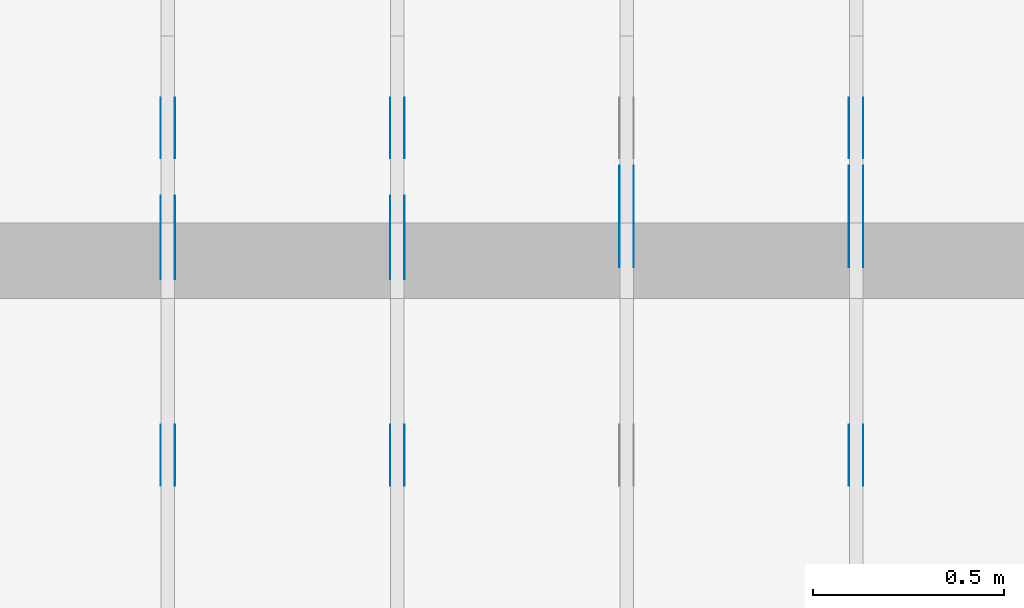
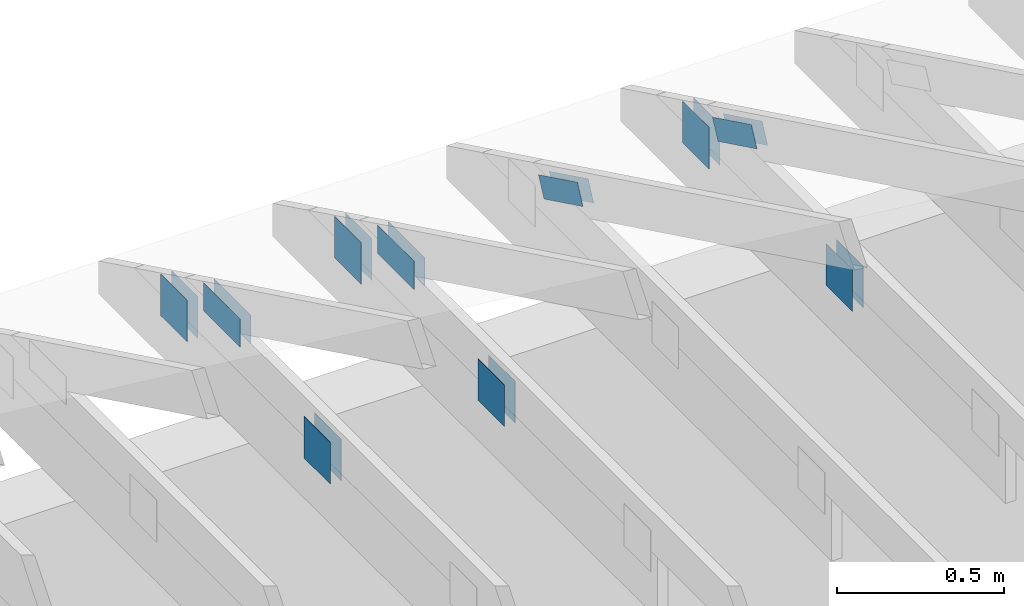
# One storey, part 94 of 159: 20 plates, 4 elements without a shape of their own.
"""IFC2X3 building model written with IfcOpenShell, lengths in millimetres."""

from ifc_helpers import new_model, si_unit, frame, origin, origin_with_axes, origin_2d, place, context, project, spatial, faceted_brep, element, aggregate, save


model = new_model("IFC2X3")

# Units and contexts
model_context = context("Model", 3, precision=1e-05, world=origin())
plan_context = context("Plan", 2, precision=1e-05, world=origin_2d())
ifc_project = project(units=[si_unit("LENGTHUNIT", "METRE", prefix="MILLI"), si_unit("AREAUNIT", "SQUARE_METRE"), si_unit("VOLUMEUNIT", "CUBIC_METRE"), si_unit("SOLIDANGLEUNIT", "STERADIAN"), si_unit("PLANEANGLEUNIT", "RADIAN"), si_unit("MASSUNIT", "GRAM"), si_unit("TIMEUNIT", "SECOND"), si_unit("THERMODYNAMICTEMPERATUREUNIT", "DEGREE_CELSIUS"), si_unit("LUMINOUSINTENSITYUNIT", "LUMEN")], contexts=[model_context, plan_context])

# Site, building, storey
site_placement = place(None, origin_with_axes())
site = spatial("IfcSite", under=ifc_project, at=site_placement, CompositionType="ELEMENT")
building_placement = place(site_placement, origin_with_axes())
building = spatial("IfcBuilding", under=site, at=building_placement, Name="Plan 1", CompositionType="ELEMENT")
storey_placement = place(building_placement, origin_with_axes())
storey = spatial("IfcBuildingStorey", under=building, at=storey_placement, Name="Etasje 1", CompositionType="ELEMENT", Elevation=0.0)

# Assembly, plates
assembly_1_placement = place(storey_placement, frame((7275.0222614047525, 9699.99999999999, 1.1021457184401395e-15), z_axis=(-1.0, 1.836909530733566e-16, 6.123031769111886e-17), x_axis=(-1.836909530733566e-16, -1.0, 0.0)))
assembly_1 = element("IfcElementAssembly", 1, at=assembly_1_placement, inside=storey, Name="T2 (90)", AssemblyPlace="FACTORY", PredefinedType="TRUSS")
plate_1_placement = place(assembly_1_placement, frame((584.1466632894789, 280.2959373746887, 0.0), z_axis=(0.0, 0.0, 1.0), x_axis=(0.8987940462991671, 0.43837114678907757, 0.0)))
plate_1 = element("IfcPlate", 2, at=plate_1_placement, Name="GNT100S 76x258", context=model_context, shape_type="Brep", body=[
    faceted_brep([(257.99998123479463, 76.00002691228985, 1.0), (0.0, 76.00002691228985, 1.0), (1.3453948213282274e-05, 1.802431262376558e-05, 1.0), (257.99999468874273, 1.802431262376558e-05, 1.0), (0.0, 76.00002691228985, 0.0), (257.99998123479463, 76.00002691228985, 3.159484163061836e-14), (257.99999468874273, 0.0, 3.1594843278197396e-14), (1.3453948213282274e-05, 0.0, 1.6475790465982693e-21), (258.00000746284013, 8.521039129974861e-06, 1.1615733003639174e-30), (258.00000746284013, 8.521039130036092e-06, 1.0), (7.462840130756376e-06, 8.521039177428358e-06, 1.0), (7.462840130756376e-06, 8.521039177367127e-06, 9.4039548065783e-38), (258.00000746284013, 76.00000852103915, 0.0), (258.00000746284013, 76.00000852103915, 1.0), (258.00000746284013, 8.52103914894542e-06, 1.0), (258.00000746284013, 8.52103914894542e-06, 0.0), (7.462840130756376e-06, 76.0000085210392, 0.0), (7.462840130756376e-06, 76.0000085210392, 1.0), (258.00000746284013, 76.00000852103913, 1.0), (258.00000746284013, 76.00000852103913, -1.5777218104420236e-30), (7.462840130756377e-06, 8.521039177367129e-06, -9.4039548065783e-38), (7.4628401308176075e-06, 8.521039177367129e-06, 1.0), (7.462840140124616e-06, 76.0000085210392, 1.0), (7.4628401400633854e-06, 76.0000085210392, -5.69871103679771e-31)], [[[0, 1, 2, 3]], [[4, 5, 6, 7]], [[8, 9, 10, 11]], [[12, 13, 14, 15]], [[16, 17, 18, 19]], [[20, 21, 22, 23]]]),
])
plate_2_placement = place(assembly_1_placement, frame((584.1466632894789, 280.2959373746887, -37.0), z_axis=(0.0, 0.0, 1.0), x_axis=(0.8987940462991671, 0.43837114678907757, 0.0)))
plate_2 = element("IfcPlate", 3, at=plate_2_placement, Name="GNT100S 76x258", context=model_context, shape_type="Brep", body=[
    faceted_brep([(257.99998123479463, 76.00002691228985, 1.0), (0.0, 76.00002691228985, 1.0), (1.3453948213282274e-05, 1.802431262376558e-05, 1.0), (257.99999468874273, 1.802431262376558e-05, 1.0), (0.0, 76.00002691228985, 0.0), (257.99998123479463, 76.00002691228985, 3.159484163061836e-14), (257.99999468874273, 0.0, 3.1594843278197396e-14), (1.3453948213282274e-05, 0.0, 1.6475790465982693e-21), (258.00000746284013, 8.521039129974861e-06, 1.1615733003639174e-30), (258.00000746284013, 8.521039130036092e-06, 1.0), (7.462840130756376e-06, 8.521039177428358e-06, 1.0), (7.462840130756376e-06, 8.521039177367127e-06, 9.4039548065783e-38), (258.00000746284013, 76.00000852103915, 0.0), (258.00000746284013, 76.00000852103915, 1.0), (258.00000746284013, 8.52103914894542e-06, 1.0), (258.00000746284013, 8.52103914894542e-06, 0.0), (7.462840130756376e-06, 76.0000085210392, 0.0), (7.462840130756376e-06, 76.0000085210392, 1.0), (258.00000746284013, 76.00000852103913, 1.0), (258.00000746284013, 76.00000852103913, -1.5777218104420236e-30), (7.462840130756377e-06, 8.521039177367129e-06, -9.4039548065783e-38), (7.4628401308176075e-06, 8.521039177367129e-06, 1.0), (7.462840140124616e-06, 76.0000085210392, 1.0), (7.4628401400633854e-06, 76.0000085210392, -5.69871103679771e-31)], [[[0, 1, 2, 3]], [[4, 5, 6, 7]], [[8, 9, 10, 11]], [[12, 13, 14, 15]], [[16, 17, 18, 19]], [[20, 21, 22, 23]]]),
])
plate_3_placement = place(assembly_1_placement, frame((1227.851282296476, 147.0, 0.0), z_axis=(0.0, 0.0, 1.0), x_axis=(1.0, 0.0, 0.0)))
plate_3 = element("IfcPlate", 4, at=plate_3_placement, Name="GNT100S 152x159", context=model_context, shape_type="Brep", body=[
    faceted_brep([(159.00003606289897, 152.0, 1.0), (3.6062898971067625e-05, 152.0, 1.0), (3.6062898971067625e-05, 0.0, 1.0), (159.00003606289897, 0.0, 1.0), (3.6062898971067625e-05, 152.0, 4.4162855217223885e-21), (159.00003606289897, 152.0, 1.947124544206132e-14), (159.00003606289897, 0.0, 1.947124544206132e-14), (3.6062898971067625e-05, 0.0, 4.4162855217223885e-21), (159.0, 8.447997618295233e-14, 1.788345410772899e-30), (159.0, 8.454120650064345e-14, 1.0), (1.1247455413666031e-32, 1.1374806803930715e-13, 1.0), (0.0, 1.1368683772161603e-13, 0.0), (159.0, 152.0000000000001, 0.0), (159.0, 152.0000000000001, 1.0), (159.0, 1.1368683772161603e-13, 1.0), (159.0, 1.1368683772161603e-13, 0.0), (4.861730685829017e-63, 152.0000000000001, 0.0), (-3.7491518045553436e-33, 152.0000000000001, 1.0), (159.0, 152.0000000000001, 1.0), (159.0, 152.0000000000001, 0.0), (1.392216238198645e-29, 1.1368683772161603e-13, -8.524584255963745e-46), (6.123031769113279e-17, 1.1368683772161603e-13, 1.0), (1.8675246895791266e-14, 152.0000000000001, 1.0), (1.8614016578100147e-14, 152.0000000000001, -1.1397421485848253e-30)], [[[0, 1, 2, 3]], [[4, 5, 6, 7]], [[8, 9, 10, 11]], [[12, 13, 14, 15]], [[16, 17, 18, 19]], [[20, 21, 22, 23]]]),
])
plate_4_placement = place(assembly_1_placement, frame((1227.851282296476, 147.0, -37.0), z_axis=(0.0, 0.0, 1.0), x_axis=(1.0, 0.0, 0.0)))
plate_4 = element("IfcPlate", 5, at=plate_4_placement, Name="GNT100S 152x159", context=model_context, shape_type="Brep", body=[
    faceted_brep([(159.00003606289897, 152.0, 1.0), (3.6062898971067625e-05, 152.0, 1.0), (3.6062898971067625e-05, 0.0, 1.0), (159.00003606289897, 0.0, 1.0), (3.6062898971067625e-05, 152.0, 4.4162855217223885e-21), (159.00003606289897, 152.0, 1.947124544206132e-14), (159.00003606289897, 0.0, 1.947124544206132e-14), (3.6062898971067625e-05, 0.0, 4.4162855217223885e-21), (159.0, 8.447997618295233e-14, 1.788345410772899e-30), (159.0, 8.454120650064345e-14, 1.0), (1.1247455413666031e-32, 1.1374806803930715e-13, 1.0), (0.0, 1.1368683772161603e-13, 0.0), (159.0, 152.0000000000001, 0.0), (159.0, 152.0000000000001, 1.0), (159.0, 1.1368683772161603e-13, 1.0), (159.0, 1.1368683772161603e-13, 0.0), (4.861730685829017e-63, 152.0000000000001, 0.0), (-3.7491518045553436e-33, 152.0000000000001, 1.0), (159.0, 152.0000000000001, 1.0), (159.0, 152.0000000000001, 0.0), (1.392216238198645e-29, 1.1368683772161603e-13, -8.524584255963745e-46), (6.123031769113279e-17, 1.1368683772161603e-13, 1.0), (1.8675246895791266e-14, 152.0000000000001, 1.0), (1.8614016578100147e-14, 152.0000000000001, -1.1397421485848253e-30)], [[[0, 1, 2, 3]], [[4, 5, 6, 7]], [[8, 9, 10, 11]], [[12, 13, 14, 15]], [[16, 17, 18, 19]], [[20, 21, 22, 23]]]),
])
plate_5_placement = place(assembly_1_placement, frame((372.12651478826456, 147.0, 0.0), z_axis=(0.0, 0.0, 1.0), x_axis=(1.0, 0.0, 0.0)))
plate_5 = element("IfcPlate", 6, at=plate_5_placement, Name="GNT100S 152x159", context=model_context, shape_type="Brep", body=[
    faceted_brep([(159.0000110906417, 152.0, 1.0), (1.109064169213525e-05, 152.0, 1.0), (1.109064169213525e-05, 0.0, 1.0), (159.0000110906417, 0.0, 1.0), (1.109064169213525e-05, 152.0, 1.3581670284156189e-21), (159.0000110906417, 152.0, 1.9471242383942826e-14), (159.0000110906417, 0.0, 1.9471242383942826e-14), (1.109064169213525e-05, 0.0, 1.3581670284156189e-21), (159.0, 1.9816681390456836e-13, 1.788345410772899e-30), (159.0, 1.9822804422225948e-13, 1.0), (1.1247455413666031e-32, 2.274349057609232e-13, 1.0), (0.0, 2.2737367544323206e-13, 0.0), (159.0, 152.00000000000023, 0.0), (159.0, 152.00000000000023, 1.0), (159.0, 2.2737367544323206e-13, 1.0), (159.0, 2.2737367544323206e-13, 0.0), (0.0, 152.00000000000023, 0.0), (-3.7491518045553436e-33, 152.00000000000023, 1.0), (159.0, 152.00000000000023, 1.0), (159.0, 152.00000000000023, 0.0), (2.78443247639729e-29, 2.2737367544323206e-13, -1.704916851192749e-45), (6.123031769114671e-17, 2.2737367544323206e-13, 1.0), (1.8675246895791282e-14, 152.00000000000023, 1.0), (1.8614016578100163e-14, 152.00000000000023, -1.1397421485848262e-30)], [[[0, 1, 2, 3]], [[4, 5, 6, 7]], [[8, 9, 10, 11]], [[12, 13, 14, 15]], [[16, 17, 18, 19]], [[20, 21, 22, 23]]]),
])
plate_6_placement = place(assembly_1_placement, frame((372.12651478826456, 147.0, -37.0), z_axis=(0.0, 0.0, 1.0), x_axis=(1.0, 0.0, 0.0)))
plate_6 = element("IfcPlate", 7, at=plate_6_placement, Name="GNT100S 152x159", context=model_context, shape_type="Brep", body=[
    faceted_brep([(159.0000110906417, 152.0, 1.0), (1.109064169213525e-05, 152.0, 1.0), (1.109064169213525e-05, 0.0, 1.0), (159.0000110906417, 0.0, 1.0), (1.109064169213525e-05, 152.0, 1.3581670284156189e-21), (159.0000110906417, 152.0, 1.9471242383942826e-14), (159.0000110906417, 0.0, 1.9471242383942826e-14), (1.109064169213525e-05, 0.0, 1.3581670284156189e-21), (159.0, 1.9816681390456836e-13, 1.788345410772899e-30), (159.0, 1.9822804422225948e-13, 1.0), (1.1247455413666031e-32, 2.274349057609232e-13, 1.0), (0.0, 2.2737367544323206e-13, 0.0), (159.0, 152.00000000000023, 0.0), (159.0, 152.00000000000023, 1.0), (159.0, 2.2737367544323206e-13, 1.0), (159.0, 2.2737367544323206e-13, 0.0), (0.0, 152.00000000000023, 0.0), (-3.7491518045553436e-33, 152.00000000000023, 1.0), (159.0, 152.00000000000023, 1.0), (159.0, 152.00000000000023, 0.0), (2.78443247639729e-29, 2.2737367544323206e-13, -1.704916851192749e-45), (6.123031769114671e-17, 2.2737367544323206e-13, 1.0), (1.8675246895791282e-14, 152.00000000000023, 1.0), (1.8614016578100163e-14, 152.00000000000023, -1.1397421485848262e-30)], [[[0, 1, 2, 3]], [[4, 5, 6, 7]], [[8, 9, 10, 11]], [[12, 13, 14, 15]], [[16, 17, 18, 19]], [[20, 21, 22, 23]]]),
])
aggregate(assembly_1, [plate_1, plate_2, plate_3, plate_4, plate_5, plate_6])

assembly_2_placement = place(storey_placement, frame((6675.0222614047525, 9699.99999999999, 1.1021457184401395e-15), z_axis=(-1.0, 1.836909530733566e-16, 6.123031769111886e-17), x_axis=(-1.836909530733566e-16, -1.0, 0.0)))
assembly_2 = element("IfcElementAssembly", 8, at=assembly_2_placement, inside=storey, Name="T2 (89)", AssemblyPlace="FACTORY", PredefinedType="TRUSS")
plate_7_placement = place(assembly_2_placement, frame((584.1466632894789, 280.2959373746887, 0.0), z_axis=(0.0, 0.0, 1.0), x_axis=(0.8987940462991671, 0.43837114678907757, 0.0)))
plate_7 = element("IfcPlate", 9, at=plate_7_placement, Name="GNT100S 76x258", context=model_context, shape_type="Brep", body=[
    faceted_brep([(257.99998123479463, 76.00002691228985, 1.0), (0.0, 76.00002691228985, 1.0), (1.3453948213282274e-05, 1.802431262376558e-05, 1.0), (257.99999468874273, 1.802431262376558e-05, 1.0), (0.0, 76.00002691228985, 0.0), (257.99998123479463, 76.00002691228985, 3.159484163061836e-14), (257.99999468874273, 0.0, 3.1594843278197396e-14), (1.3453948213282274e-05, 0.0, 1.6475790465982693e-21), (258.00000746284013, 8.521039129974861e-06, 1.1615733003639174e-30), (258.00000746284013, 8.521039130036092e-06, 1.0), (7.462840130756376e-06, 8.521039177428358e-06, 1.0), (7.462840130756376e-06, 8.521039177367127e-06, 9.4039548065783e-38), (258.00000746284013, 76.00000852103915, 0.0), (258.00000746284013, 76.00000852103915, 1.0), (258.00000746284013, 8.52103914894542e-06, 1.0), (258.00000746284013, 8.52103914894542e-06, 0.0), (7.462840130756376e-06, 76.0000085210392, 0.0), (7.462840130756376e-06, 76.0000085210392, 1.0), (258.00000746284013, 76.00000852103913, 1.0), (258.00000746284013, 76.00000852103913, -1.5777218104420236e-30), (7.462840130756377e-06, 8.521039177367129e-06, -9.4039548065783e-38), (7.4628401308176075e-06, 8.521039177367129e-06, 1.0), (7.462840140124616e-06, 76.0000085210392, 1.0), (7.4628401400633854e-06, 76.0000085210392, -5.69871103679771e-31)], [[[0, 1, 2, 3]], [[4, 5, 6, 7]], [[8, 9, 10, 11]], [[12, 13, 14, 15]], [[16, 17, 18, 19]], [[20, 21, 22, 23]]]),
])
plate_8_placement = place(assembly_2_placement, frame((584.1466632894789, 280.2959373746887, -37.0), z_axis=(0.0, 0.0, 1.0), x_axis=(0.8987940462991671, 0.43837114678907757, 0.0)))
plate_8 = element("IfcPlate", 10, at=plate_8_placement, Name="GNT100S 76x258", context=model_context, shape_type="Brep", body=[
    faceted_brep([(257.99998123479463, 76.00002691228985, 1.0), (0.0, 76.00002691228985, 1.0), (1.3453948213282274e-05, 1.802431262376558e-05, 1.0), (257.99999468874273, 1.802431262376558e-05, 1.0), (0.0, 76.00002691228985, 0.0), (257.99998123479463, 76.00002691228985, 3.159484163061836e-14), (257.99999468874273, 0.0, 3.1594843278197396e-14), (1.3453948213282274e-05, 0.0, 1.6475790465982693e-21), (258.00000746284013, 8.521039129974861e-06, 1.1615733003639174e-30), (258.00000746284013, 8.521039130036092e-06, 1.0), (7.462840130756376e-06, 8.521039177428358e-06, 1.0), (7.462840130756376e-06, 8.521039177367127e-06, 9.4039548065783e-38), (258.00000746284013, 76.00000852103915, 0.0), (258.00000746284013, 76.00000852103915, 1.0), (258.00000746284013, 8.52103914894542e-06, 1.0), (258.00000746284013, 8.52103914894542e-06, 0.0), (7.462840130756376e-06, 76.0000085210392, 0.0), (7.462840130756376e-06, 76.0000085210392, 1.0), (258.00000746284013, 76.00000852103913, 1.0), (258.00000746284013, 76.00000852103913, -1.5777218104420236e-30), (7.462840130756377e-06, 8.521039177367129e-06, -9.4039548065783e-38), (7.4628401308176075e-06, 8.521039177367129e-06, 1.0), (7.462840140124616e-06, 76.0000085210392, 1.0), (7.4628401400633854e-06, 76.0000085210392, -5.69871103679771e-31)], [[[0, 1, 2, 3]], [[4, 5, 6, 7]], [[8, 9, 10, 11]], [[12, 13, 14, 15]], [[16, 17, 18, 19]], [[20, 21, 22, 23]]]),
])
aggregate(assembly_2, [plate_7, plate_8])

assembly_3_placement = place(storey_placement, frame((5475.0222614047525, 9699.99999999999, 1.1021457184401395e-15), z_axis=(-1.0, 1.836909530733566e-16, 6.123031769111886e-17), x_axis=(-1.836909530733566e-16, -1.0, 0.0)))
assembly_3 = element("IfcElementAssembly", 11, at=assembly_3_placement, inside=storey, Name="T1 (87)", AssemblyPlace="FACTORY", PredefinedType="TRUSS")
plate_9_placement = place(assembly_3_placement, frame((628.6262642368674, 319.5, 0.0), z_axis=(0.0, 0.0, 1.0), x_axis=(1.0, 0.0, 0.0)))
plate_9 = element("IfcPlate", 12, at=plate_9_placement, Name="GNT100S 103x218", context=model_context, shape_type="Brep", body=[
    faceted_brep([(218.00001750141382, 103.0, 1.0), (1.7501413822174072e-05, 103.0, 1.0), (1.7501413822174072e-05, 0.0, 1.0), (218.00001750141382, 0.0, 1.0), (1.7501413822174072e-05, 103.0, 2.1432342567509146e-21), (218.00001750141382, 103.0, 2.669642065656208e-14), (218.00001750141382, 0.0, 2.669642065656208e-14), (1.7501413822174072e-05, 0.0, 2.1432342567509146e-21), (218.0, 1.0399803305853605e-12, 2.4519452801791947e-30), (218.0, 1.0400415609030517e-12, 1.0), (1.1247455413666031e-32, 1.0800861886730434e-12, 1.0), (0.0, 1.0800249583553523e-12, 0.0), (218.0, 103.00000000000108, 0.0), (218.0, 103.00000000000108, 1.0), (218.0, 1.0800249583553523e-12, 1.0), (218.0, 1.0800249583553523e-12, 0.0), (0.0, 103.00000000000108, 0.0), (-3.7491518045553436e-33, 103.00000000000108, 1.0), (218.0, 103.00000000000107, 1.0), (218.0, 103.00000000000107, -7.888609052210118e-31), (1.3226054262887128e-28, 1.0800249583553523e-12, -8.098355043165558e-45), (6.123031769125112e-17, 1.0800249583553523e-12, 1.0), (1.2674675762061737e-14, 103.00000000000108, 1.0), (1.2613445444370618e-14, 103.00000000000108, -7.723252717384088e-31)], [[[0, 1, 2, 3]], [[4, 5, 6, 7]], [[8, 9, 10, 11]], [[12, 13, 14, 15]], [[16, 17, 18, 19]], [[20, 21, 22, 23]]]),
])
plate_10_placement = place(assembly_3_placement, frame((628.6262642368674, 319.5, -37.0), z_axis=(0.0, 0.0, 1.0), x_axis=(1.0, 0.0, 0.0)))
plate_10 = element("IfcPlate", 13, at=plate_10_placement, Name="GNT100S 103x218", context=model_context, shape_type="Brep", body=[
    faceted_brep([(218.00001750141382, 103.0, 1.0), (1.7501413822174072e-05, 103.0, 1.0), (1.7501413822174072e-05, 0.0, 1.0), (218.00001750141382, 0.0, 1.0), (1.7501413822174072e-05, 103.0, 2.1432342567509146e-21), (218.00001750141382, 103.0, 2.669642065656208e-14), (218.00001750141382, 0.0, 2.669642065656208e-14), (1.7501413822174072e-05, 0.0, 2.1432342567509146e-21), (218.0, 1.0399803305853605e-12, 2.4519452801791947e-30), (218.0, 1.0400415609030517e-12, 1.0), (1.1247455413666031e-32, 1.0800861886730434e-12, 1.0), (0.0, 1.0800249583553523e-12, 0.0), (218.0, 103.00000000000108, 0.0), (218.0, 103.00000000000108, 1.0), (218.0, 1.0800249583553523e-12, 1.0), (218.0, 1.0800249583553523e-12, 0.0), (0.0, 103.00000000000108, 0.0), (-3.7491518045553436e-33, 103.00000000000108, 1.0), (218.0, 103.00000000000107, 1.0), (218.0, 103.00000000000107, -7.888609052210118e-31), (1.3226054262887128e-28, 1.0800249583553523e-12, -8.098355043165558e-45), (6.123031769125112e-17, 1.0800249583553523e-12, 1.0), (1.2674675762061737e-14, 103.00000000000108, 1.0), (1.2613445444370618e-14, 103.00000000000108, -7.723252717384088e-31)], [[[0, 1, 2, 3]], [[4, 5, 6, 7]], [[8, 9, 10, 11]], [[12, 13, 14, 15]], [[16, 17, 18, 19]], [[20, 21, 22, 23]]]),
])
plate_11_placement = place(assembly_3_placement, frame((1227.851282296476, 147.0, 0.0), z_axis=(0.0, 0.0, 1.0), x_axis=(1.0, 0.0, 0.0)))
plate_11 = element("IfcPlate", 14, at=plate_11_placement, Name="GNT100S 152x159", context=model_context, shape_type="Brep", body=[
    faceted_brep([(159.00003606289897, 152.0, 1.0), (3.6062898971067625e-05, 152.0, 1.0), (3.6062898971067625e-05, 0.0, 1.0), (159.00003606289897, 0.0, 1.0), (3.6062898971067625e-05, 152.0, 4.4162855217223885e-21), (159.00003606289897, 152.0, 1.947124544206132e-14), (159.00003606289897, 0.0, 1.947124544206132e-14), (3.6062898971067625e-05, 0.0, 4.4162855217223885e-21), (159.0, 8.447997618295233e-14, 1.788345410772899e-30), (159.0, 8.454120650064345e-14, 1.0), (1.1247455413666031e-32, 1.1374806803930715e-13, 1.0), (0.0, 1.1368683772161603e-13, 0.0), (159.0, 152.0000000000001, 0.0), (159.0, 152.0000000000001, 1.0), (159.0, 1.1368683772161603e-13, 1.0), (159.0, 1.1368683772161603e-13, 0.0), (4.861730685829017e-63, 152.0000000000001, 0.0), (-3.7491518045553436e-33, 152.0000000000001, 1.0), (159.0, 152.0000000000001, 1.0), (159.0, 152.0000000000001, 0.0), (1.392216238198645e-29, 1.1368683772161603e-13, -8.524584255963745e-46), (6.123031769113279e-17, 1.1368683772161603e-13, 1.0), (1.8675246895791266e-14, 152.0000000000001, 1.0), (1.8614016578100147e-14, 152.0000000000001, -1.1397421485848253e-30)], [[[0, 1, 2, 3]], [[4, 5, 6, 7]], [[8, 9, 10, 11]], [[12, 13, 14, 15]], [[16, 17, 18, 19]], [[20, 21, 22, 23]]]),
])
plate_12_placement = place(assembly_3_placement, frame((1227.851282296476, 147.0, -37.0), z_axis=(0.0, 0.0, 1.0), x_axis=(1.0, 0.0, 0.0)))
plate_12 = element("IfcPlate", 15, at=plate_12_placement, Name="GNT100S 152x159", context=model_context, shape_type="Brep", body=[
    faceted_brep([(159.00003606289897, 152.0, 1.0), (3.6062898971067625e-05, 152.0, 1.0), (3.6062898971067625e-05, 0.0, 1.0), (159.00003606289897, 0.0, 1.0), (3.6062898971067625e-05, 152.0, 4.4162855217223885e-21), (159.00003606289897, 152.0, 1.947124544206132e-14), (159.00003606289897, 0.0, 1.947124544206132e-14), (3.6062898971067625e-05, 0.0, 4.4162855217223885e-21), (159.0, 8.447997618295233e-14, 1.788345410772899e-30), (159.0, 8.454120650064345e-14, 1.0), (1.1247455413666031e-32, 1.1374806803930715e-13, 1.0), (0.0, 1.1368683772161603e-13, 0.0), (159.0, 152.0000000000001, 0.0), (159.0, 152.0000000000001, 1.0), (159.0, 1.1368683772161603e-13, 1.0), (159.0, 1.1368683772161603e-13, 0.0), (4.861730685829017e-63, 152.0000000000001, 0.0), (-3.7491518045553436e-33, 152.0000000000001, 1.0), (159.0, 152.0000000000001, 1.0), (159.0, 152.0000000000001, 0.0), (1.392216238198645e-29, 1.1368683772161603e-13, -8.524584255963745e-46), (6.123031769113279e-17, 1.1368683772161603e-13, 1.0), (1.8675246895791266e-14, 152.0000000000001, 1.0), (1.8614016578100147e-14, 152.0000000000001, -1.1397421485848253e-30)], [[[0, 1, 2, 3]], [[4, 5, 6, 7]], [[8, 9, 10, 11]], [[12, 13, 14, 15]], [[16, 17, 18, 19]], [[20, 21, 22, 23]]]),
])
plate_13_placement = place(assembly_3_placement, frame((372.12651478826456, 147.0, 0.0), z_axis=(0.0, 0.0, 1.0), x_axis=(1.0, 0.0, 0.0)))
plate_13 = element("IfcPlate", 16, at=plate_13_placement, Name="GNT100S 152x159", context=model_context, shape_type="Brep", body=[
    faceted_brep([(159.0000110906417, 152.0, 1.0), (1.109064169213525e-05, 152.0, 1.0), (1.109064169213525e-05, 0.0, 1.0), (159.0000110906417, 0.0, 1.0), (1.109064169213525e-05, 152.0, 1.3581670284156189e-21), (159.0000110906417, 152.0, 1.9471242383942826e-14), (159.0000110906417, 0.0, 1.9471242383942826e-14), (1.109064169213525e-05, 0.0, 1.3581670284156189e-21), (159.0, 1.9816681390456836e-13, 1.788345410772899e-30), (159.0, 1.9822804422225948e-13, 1.0), (1.1247455413666031e-32, 2.274349057609232e-13, 1.0), (0.0, 2.2737367544323206e-13, 0.0), (159.0, 152.00000000000023, 0.0), (159.0, 152.00000000000023, 1.0), (159.0, 2.2737367544323206e-13, 1.0), (159.0, 2.2737367544323206e-13, 0.0), (0.0, 152.00000000000023, 0.0), (-3.7491518045553436e-33, 152.00000000000023, 1.0), (159.0, 152.00000000000023, 1.0), (159.0, 152.00000000000023, 0.0), (2.78443247639729e-29, 2.2737367544323206e-13, -1.704916851192749e-45), (6.123031769114671e-17, 2.2737367544323206e-13, 1.0), (1.8675246895791282e-14, 152.00000000000023, 1.0), (1.8614016578100163e-14, 152.00000000000023, -1.1397421485848262e-30)], [[[0, 1, 2, 3]], [[4, 5, 6, 7]], [[8, 9, 10, 11]], [[12, 13, 14, 15]], [[16, 17, 18, 19]], [[20, 21, 22, 23]]]),
])
plate_14_placement = place(assembly_3_placement, frame((372.12651478826456, 147.0, -37.0), z_axis=(0.0, 0.0, 1.0), x_axis=(1.0, 0.0, 0.0)))
plate_14 = element("IfcPlate", 17, at=plate_14_placement, Name="GNT100S 152x159", context=model_context, shape_type="Brep", body=[
    faceted_brep([(159.0000110906417, 152.0, 1.0), (1.109064169213525e-05, 152.0, 1.0), (1.109064169213525e-05, 0.0, 1.0), (159.0000110906417, 0.0, 1.0), (1.109064169213525e-05, 152.0, 1.3581670284156189e-21), (159.0000110906417, 152.0, 1.9471242383942826e-14), (159.0000110906417, 0.0, 1.9471242383942826e-14), (1.109064169213525e-05, 0.0, 1.3581670284156189e-21), (159.0, 1.9816681390456836e-13, 1.788345410772899e-30), (159.0, 1.9822804422225948e-13, 1.0), (1.1247455413666031e-32, 2.274349057609232e-13, 1.0), (0.0, 2.2737367544323206e-13, 0.0), (159.0, 152.00000000000023, 0.0), (159.0, 152.00000000000023, 1.0), (159.0, 2.2737367544323206e-13, 1.0), (159.0, 2.2737367544323206e-13, 0.0), (0.0, 152.00000000000023, 0.0), (-3.7491518045553436e-33, 152.00000000000023, 1.0), (159.0, 152.00000000000023, 1.0), (159.0, 152.00000000000023, 0.0), (2.78443247639729e-29, 2.2737367544323206e-13, -1.704916851192749e-45), (6.123031769114671e-17, 2.2737367544323206e-13, 1.0), (1.8675246895791282e-14, 152.00000000000023, 1.0), (1.8614016578100163e-14, 152.00000000000023, -1.1397421485848262e-30)], [[[0, 1, 2, 3]], [[4, 5, 6, 7]], [[8, 9, 10, 11]], [[12, 13, 14, 15]], [[16, 17, 18, 19]], [[20, 21, 22, 23]]]),
])
aggregate(assembly_3, [plate_9, plate_10, plate_11, plate_12, plate_13, plate_14])

assembly_4_placement = place(storey_placement, frame((6075.0222614047525, 9699.99999999999, 1.1021457184401395e-15), z_axis=(-1.0, 1.836909530733566e-16, 6.123031769111886e-17), x_axis=(-1.836909530733566e-16, -1.0, 0.0)))
assembly_4 = element("IfcElementAssembly", 18, at=assembly_4_placement, inside=storey, Name="T1 (88)", AssemblyPlace="FACTORY", PredefinedType="TRUSS")
plate_15_placement = place(assembly_4_placement, frame((628.6262642368674, 319.5, 0.0), z_axis=(0.0, 0.0, 1.0), x_axis=(1.0, 0.0, 0.0)))
plate_15 = element("IfcPlate", 19, at=plate_15_placement, Name="GNT100S 103x218", context=model_context, shape_type="Brep", body=[
    faceted_brep([(218.00001750141382, 103.0, 1.0), (1.7501413822174072e-05, 103.0, 1.0), (1.7501413822174072e-05, 0.0, 1.0), (218.00001750141382, 0.0, 1.0), (1.7501413822174072e-05, 103.0, 2.1432342567509146e-21), (218.00001750141382, 103.0, 2.669642065656208e-14), (218.00001750141382, 0.0, 2.669642065656208e-14), (1.7501413822174072e-05, 0.0, 2.1432342567509146e-21), (218.0, 1.0399803305853605e-12, 2.4519452801791947e-30), (218.0, 1.0400415609030517e-12, 1.0), (1.1247455413666031e-32, 1.0800861886730434e-12, 1.0), (0.0, 1.0800249583553523e-12, 0.0), (218.0, 103.00000000000108, 0.0), (218.0, 103.00000000000108, 1.0), (218.0, 1.0800249583553523e-12, 1.0), (218.0, 1.0800249583553523e-12, 0.0), (0.0, 103.00000000000108, 0.0), (-3.7491518045553436e-33, 103.00000000000108, 1.0), (218.0, 103.00000000000107, 1.0), (218.0, 103.00000000000107, -7.888609052210118e-31), (1.3226054262887128e-28, 1.0800249583553523e-12, -8.098355043165558e-45), (6.123031769125112e-17, 1.0800249583553523e-12, 1.0), (1.2674675762061737e-14, 103.00000000000108, 1.0), (1.2613445444370618e-14, 103.00000000000108, -7.723252717384088e-31)], [[[0, 1, 2, 3]], [[4, 5, 6, 7]], [[8, 9, 10, 11]], [[12, 13, 14, 15]], [[16, 17, 18, 19]], [[20, 21, 22, 23]]]),
])
plate_16_placement = place(assembly_4_placement, frame((628.6262642368674, 319.5, -37.0), z_axis=(0.0, 0.0, 1.0), x_axis=(1.0, 0.0, 0.0)))
plate_16 = element("IfcPlate", 20, at=plate_16_placement, Name="GNT100S 103x218", context=model_context, shape_type="Brep", body=[
    faceted_brep([(218.00001750141382, 103.0, 1.0), (1.7501413822174072e-05, 103.0, 1.0), (1.7501413822174072e-05, 0.0, 1.0), (218.00001750141382, 0.0, 1.0), (1.7501413822174072e-05, 103.0, 2.1432342567509146e-21), (218.00001750141382, 103.0, 2.669642065656208e-14), (218.00001750141382, 0.0, 2.669642065656208e-14), (1.7501413822174072e-05, 0.0, 2.1432342567509146e-21), (218.0, 1.0399803305853605e-12, 2.4519452801791947e-30), (218.0, 1.0400415609030517e-12, 1.0), (1.1247455413666031e-32, 1.0800861886730434e-12, 1.0), (0.0, 1.0800249583553523e-12, 0.0), (218.0, 103.00000000000108, 0.0), (218.0, 103.00000000000108, 1.0), (218.0, 1.0800249583553523e-12, 1.0), (218.0, 1.0800249583553523e-12, 0.0), (0.0, 103.00000000000108, 0.0), (-3.7491518045553436e-33, 103.00000000000108, 1.0), (218.0, 103.00000000000107, 1.0), (218.0, 103.00000000000107, -7.888609052210118e-31), (1.3226054262887128e-28, 1.0800249583553523e-12, -8.098355043165558e-45), (6.123031769125112e-17, 1.0800249583553523e-12, 1.0), (1.2674675762061737e-14, 103.00000000000108, 1.0), (1.2613445444370618e-14, 103.00000000000108, -7.723252717384088e-31)], [[[0, 1, 2, 3]], [[4, 5, 6, 7]], [[8, 9, 10, 11]], [[12, 13, 14, 15]], [[16, 17, 18, 19]], [[20, 21, 22, 23]]]),
])
plate_17_placement = place(assembly_4_placement, frame((1227.851282296476, 147.0, 0.0), z_axis=(0.0, 0.0, 1.0), x_axis=(1.0, 0.0, 0.0)))
plate_17 = element("IfcPlate", 21, at=plate_17_placement, Name="GNT100S 152x159", context=model_context, shape_type="Brep", body=[
    faceted_brep([(159.00003606289897, 152.0, 1.0), (3.6062898971067625e-05, 152.0, 1.0), (3.6062898971067625e-05, 0.0, 1.0), (159.00003606289897, 0.0, 1.0), (3.6062898971067625e-05, 152.0, 4.4162855217223885e-21), (159.00003606289897, 152.0, 1.947124544206132e-14), (159.00003606289897, 0.0, 1.947124544206132e-14), (3.6062898971067625e-05, 0.0, 4.4162855217223885e-21), (159.0, 8.447997618295233e-14, 1.788345410772899e-30), (159.0, 8.454120650064345e-14, 1.0), (1.1247455413666031e-32, 1.1374806803930715e-13, 1.0), (0.0, 1.1368683772161603e-13, 0.0), (159.0, 152.0000000000001, 0.0), (159.0, 152.0000000000001, 1.0), (159.0, 1.1368683772161603e-13, 1.0), (159.0, 1.1368683772161603e-13, 0.0), (4.861730685829017e-63, 152.0000000000001, 0.0), (-3.7491518045553436e-33, 152.0000000000001, 1.0), (159.0, 152.0000000000001, 1.0), (159.0, 152.0000000000001, 0.0), (1.392216238198645e-29, 1.1368683772161603e-13, -8.524584255963745e-46), (6.123031769113279e-17, 1.1368683772161603e-13, 1.0), (1.8675246895791266e-14, 152.0000000000001, 1.0), (1.8614016578100147e-14, 152.0000000000001, -1.1397421485848253e-30)], [[[0, 1, 2, 3]], [[4, 5, 6, 7]], [[8, 9, 10, 11]], [[12, 13, 14, 15]], [[16, 17, 18, 19]], [[20, 21, 22, 23]]]),
])
plate_18_placement = place(assembly_4_placement, frame((1227.851282296476, 147.0, -37.0), z_axis=(0.0, 0.0, 1.0), x_axis=(1.0, 0.0, 0.0)))
plate_18 = element("IfcPlate", 22, at=plate_18_placement, Name="GNT100S 152x159", context=model_context, shape_type="Brep", body=[
    faceted_brep([(159.00003606289897, 152.0, 1.0), (3.6062898971067625e-05, 152.0, 1.0), (3.6062898971067625e-05, 0.0, 1.0), (159.00003606289897, 0.0, 1.0), (3.6062898971067625e-05, 152.0, 4.4162855217223885e-21), (159.00003606289897, 152.0, 1.947124544206132e-14), (159.00003606289897, 0.0, 1.947124544206132e-14), (3.6062898971067625e-05, 0.0, 4.4162855217223885e-21), (159.0, 8.447997618295233e-14, 1.788345410772899e-30), (159.0, 8.454120650064345e-14, 1.0), (1.1247455413666031e-32, 1.1374806803930715e-13, 1.0), (0.0, 1.1368683772161603e-13, 0.0), (159.0, 152.0000000000001, 0.0), (159.0, 152.0000000000001, 1.0), (159.0, 1.1368683772161603e-13, 1.0), (159.0, 1.1368683772161603e-13, 0.0), (4.861730685829017e-63, 152.0000000000001, 0.0), (-3.7491518045553436e-33, 152.0000000000001, 1.0), (159.0, 152.0000000000001, 1.0), (159.0, 152.0000000000001, 0.0), (1.392216238198645e-29, 1.1368683772161603e-13, -8.524584255963745e-46), (6.123031769113279e-17, 1.1368683772161603e-13, 1.0), (1.8675246895791266e-14, 152.0000000000001, 1.0), (1.8614016578100147e-14, 152.0000000000001, -1.1397421485848253e-30)], [[[0, 1, 2, 3]], [[4, 5, 6, 7]], [[8, 9, 10, 11]], [[12, 13, 14, 15]], [[16, 17, 18, 19]], [[20, 21, 22, 23]]]),
])
plate_19_placement = place(assembly_4_placement, frame((372.12651478826456, 147.0, 0.0), z_axis=(0.0, 0.0, 1.0), x_axis=(1.0, 0.0, 0.0)))
plate_19 = element("IfcPlate", 23, at=plate_19_placement, Name="GNT100S 152x159", context=model_context, shape_type="Brep", body=[
    faceted_brep([(159.0000110906417, 152.0, 1.0), (1.109064169213525e-05, 152.0, 1.0), (1.109064169213525e-05, 0.0, 1.0), (159.0000110906417, 0.0, 1.0), (1.109064169213525e-05, 152.0, 1.3581670284156189e-21), (159.0000110906417, 152.0, 1.9471242383942826e-14), (159.0000110906417, 0.0, 1.9471242383942826e-14), (1.109064169213525e-05, 0.0, 1.3581670284156189e-21), (159.0, 1.9816681390456836e-13, 1.788345410772899e-30), (159.0, 1.9822804422225948e-13, 1.0), (1.1247455413666031e-32, 2.274349057609232e-13, 1.0), (0.0, 2.2737367544323206e-13, 0.0), (159.0, 152.00000000000023, 0.0), (159.0, 152.00000000000023, 1.0), (159.0, 2.2737367544323206e-13, 1.0), (159.0, 2.2737367544323206e-13, 0.0), (0.0, 152.00000000000023, 0.0), (-3.7491518045553436e-33, 152.00000000000023, 1.0), (159.0, 152.00000000000023, 1.0), (159.0, 152.00000000000023, 0.0), (2.78443247639729e-29, 2.2737367544323206e-13, -1.704916851192749e-45), (6.123031769114671e-17, 2.2737367544323206e-13, 1.0), (1.8675246895791282e-14, 152.00000000000023, 1.0), (1.8614016578100163e-14, 152.00000000000023, -1.1397421485848262e-30)], [[[0, 1, 2, 3]], [[4, 5, 6, 7]], [[8, 9, 10, 11]], [[12, 13, 14, 15]], [[16, 17, 18, 19]], [[20, 21, 22, 23]]]),
])
plate_20_placement = place(assembly_4_placement, frame((372.12651478826456, 147.0, -37.0), z_axis=(0.0, 0.0, 1.0), x_axis=(1.0, 0.0, 0.0)))
plate_20 = element("IfcPlate", 24, at=plate_20_placement, Name="GNT100S 152x159", context=model_context, shape_type="Brep", body=[
    faceted_brep([(159.0000110906417, 152.0, 1.0), (1.109064169213525e-05, 152.0, 1.0), (1.109064169213525e-05, 0.0, 1.0), (159.0000110906417, 0.0, 1.0), (1.109064169213525e-05, 152.0, 1.3581670284156189e-21), (159.0000110906417, 152.0, 1.9471242383942826e-14), (159.0000110906417, 0.0, 1.9471242383942826e-14), (1.109064169213525e-05, 0.0, 1.3581670284156189e-21), (159.0, 1.9816681390456836e-13, 1.788345410772899e-30), (159.0, 1.9822804422225948e-13, 1.0), (1.1247455413666031e-32, 2.274349057609232e-13, 1.0), (0.0, 2.2737367544323206e-13, 0.0), (159.0, 152.00000000000023, 0.0), (159.0, 152.00000000000023, 1.0), (159.0, 2.2737367544323206e-13, 1.0), (159.0, 2.2737367544323206e-13, 0.0), (0.0, 152.00000000000023, 0.0), (-3.7491518045553436e-33, 152.00000000000023, 1.0), (159.0, 152.00000000000023, 1.0), (159.0, 152.00000000000023, 0.0), (2.78443247639729e-29, 2.2737367544323206e-13, -1.704916851192749e-45), (6.123031769114671e-17, 2.2737367544323206e-13, 1.0), (1.8675246895791282e-14, 152.00000000000023, 1.0), (1.8614016578100163e-14, 152.00000000000023, -1.1397421485848262e-30)], [[[0, 1, 2, 3]], [[4, 5, 6, 7]], [[8, 9, 10, 11]], [[12, 13, 14, 15]], [[16, 17, 18, 19]], [[20, 21, 22, 23]]]),
])
aggregate(assembly_4, [plate_15, plate_16, plate_17, plate_18, plate_19, plate_20])

save(model, "model.ifc")
